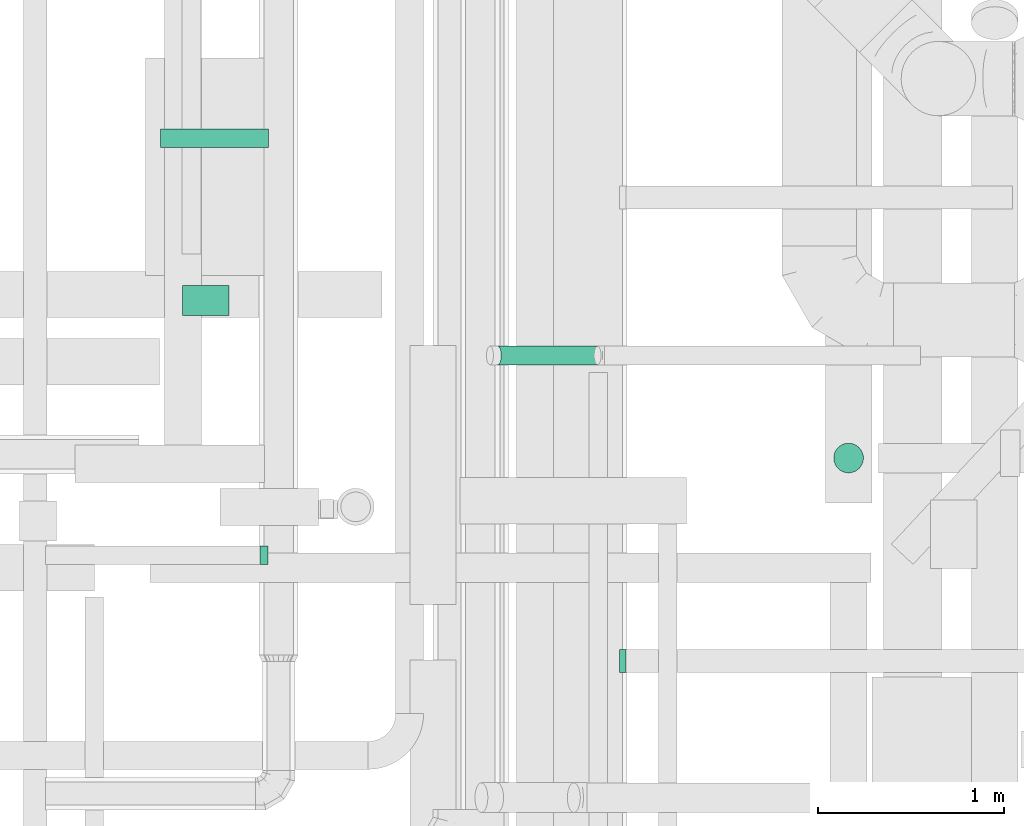
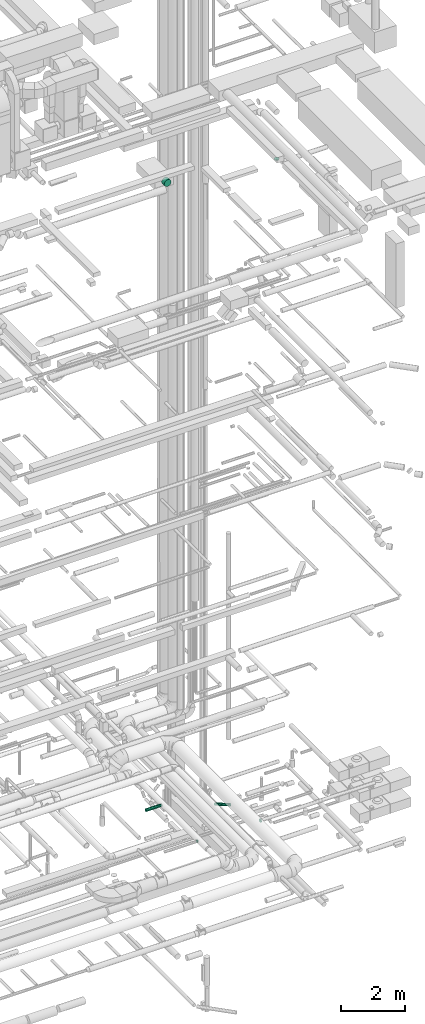
# One storey, part 214 of 337: 4 flow segments, 2 flow fittings.
"""IFC2X3 building model written with IfcOpenShell, lengths in millimetres."""

import ifcopenshell
import ifcopenshell.guid

model = None  # the IFC model being written
_history = None  # IfcOwnerHistory: only IFC2X3 demands one
_inside = {}  # id of a spatial element -> (the spatial element, [elements in it])
_under = {}  # id of a project, library or spatial element -> (it, [spatial elements below it])
_declared = {}  # id of a project -> (the project, [libraries it declares])
_typed = {}  # id of a type object -> (the type object, [elements of that type])
_made_of = {}  # id of a material, layer set ... -> (it, [elements and type objects made of it])


def new_model(schema):
    """Start an empty IFC model of exactly this schema.

    Asked for "IFC4X3", IfcOpenShell would pick the latest addendum, in which some entities
    have other attributes; the version numbers below select the first issue.
    IFC2X3 requires an IfcOwnerHistory on every rooted entity: one is made here for all.
    """
    global model, _history
    if schema == "IFC4X3":
        model = ifcopenshell.file(schema_version=(4, 3, 0, 0))
    else:
        model = ifcopenshell.file(schema=schema)
    _inside.clear()
    _under.clear()
    _declared.clear()
    _typed.clear()
    _made_of.clear()
    _history = None
    if model.schema == "IFC2X3":
        org = make("IfcOrganization", Name="unknown")
        user = make(
            "IfcPersonAndOrganization",
            ThePerson=make("IfcPerson", FamilyName="unknown"),
            TheOrganization=org,
        )
        app = make(
            "IfcApplication",
            ApplicationDeveloper=org,
            Version="unknown",
            ApplicationFullName="unknown",
            ApplicationIdentifier="unknown",
        )
        _history = make(
            "IfcOwnerHistory",
            OwningUser=user,
            OwningApplication=app,
            ChangeAction="ADDED",
            CreationDate=0,
        )
    return model


def make(cls, **values):
    """One entity of the class cls with the attributes given. An attribute that is None is left unset."""
    return model.create_entity(
        cls, **{name: value for name, value in values.items() if value is not None}
    )


def entity(cls, *values):
    """Any entity or typed value of the class cls, its attributes in the order of the schema. None: left unset."""
    e = model.create_entity(cls)
    for i, value in enumerate(values):
        if value is not None:
            e[i] = value
    return e


def rooted(cls, **values):
    """An entity with a GlobalId (a new one), such as an element, a storey or a relation."""
    return make(cls, GlobalId=ifcopenshell.guid.new(), OwnerHistory=_history, **values)


def si_unit(unit_type, name, prefix=None):
    """IfcSIUnit, for example si_unit("LENGTHUNIT", "METRE", prefix="MILLI")."""
    return make("IfcSIUnit", UnitType=unit_type, Prefix=prefix, Name=name)


def converted_unit(unit_type, name, factor, base, dimensions=None, offset=None):
    """IfcConversionBasedUnit, such as the inch: factor (a typed value) times the base unit."""
    return make(
        "IfcConversionBasedUnit"
        if offset is None
        else "IfcConversionBasedUnitWithOffset",
        ConversionOffset=offset,
        Dimensions=None
        if dimensions is None
        else entity("IfcDimensionalExponents", *dimensions),
        UnitType=unit_type,
        Name=name,
        ConversionFactor=make(
            "IfcMeasureWithUnit", ValueComponent=factor, UnitComponent=base
        ),
    )


def derived_unit(unit_type, elements):
    """IfcDerivedUnit: a product of units, each with its exponent."""
    return make(
        "IfcDerivedUnit",
        Elements=[
            make("IfcDerivedUnitElement", Unit=unit, Exponent=power)
            for unit, power in elements
        ],
        UnitType=unit_type,
    )


def assignment(units):
    """IfcUnitAssignment: the units of a project."""
    return None if units is None else make("IfcUnitAssignment", Units=units)


def point(xyz):
    """IfcCartesianPoint."""
    return None if xyz is None else make("IfcCartesianPoint", Coordinates=xyz)


def direction(xyz):
    """IfcDirection."""
    return None if xyz is None else make("IfcDirection", DirectionRatios=xyz)


def frame(location, z_axis=None, x_axis=None):
    """IfcAxis2Placement3D, a coordinate frame: its origin and axes. An axis left out is left unset."""
    return make(
        "IfcAxis2Placement3D",
        Location=point(location),
        Axis=direction(z_axis),
        RefDirection=direction(x_axis),
    )


def frame_2d(location, x_axis=None):
    """IfcAxis2Placement2D, a coordinate frame in the plane: its origin and x axis."""
    return make(
        "IfcAxis2Placement2D", Location=point(location), RefDirection=direction(x_axis)
    )


def origin():
    """The frame at (0, 0, 0) with its axes left unset."""
    return frame((0.0, 0.0, 0.0))


def origin_2d_with_axis():
    """The frame at (0, 0) in the plane with the x axis (1, 0) written out."""
    return frame_2d((0.0, 0.0), x_axis=(1.0, 0.0))


def place(relative_to, where):
    """IfcLocalPlacement: puts the frame where relative to a parent placement (None: the world)."""
    return make(
        "IfcLocalPlacement", PlacementRelTo=relative_to, RelativePlacement=where
    )


def context(
    kind, dimensions, precision=None, world=None, true_north=None, identifier=None
):
    """IfcGeometricRepresentationContext, for example the 3D "Model" context."""
    return make(
        "IfcGeometricRepresentationContext",
        ContextIdentifier=identifier,
        ContextType=kind,
        CoordinateSpaceDimension=dimensions,
        Precision=precision,
        WorldCoordinateSystem=world,
        TrueNorth=true_north,
    )


def subcontext(parent, identifier, kind, view, scale=None):
    """IfcGeometricRepresentationSubContext, for example "Body" below "Model"."""
    return make(
        "IfcGeometricRepresentationSubContext",
        ContextIdentifier=identifier,
        ContextType=kind,
        ParentContext=parent,
        TargetScale=scale,
        TargetView=view,
    )


def project(units=None, contexts=None):
    """IfcProject with its units and contexts."""
    return rooted(
        "IfcProject",
        Name="project",
        RepresentationContexts=contexts,
        UnitsInContext=assignment(units),
    )


def spatial(cls, under=None, at=None, **own):
    """A site, building, storey or space (cls), placed at a placement, below another one or the project."""
    s = rooted(cls, ObjectPlacement=at, **own)
    if under is not None:
        _under.setdefault(under.id(), (under, []))[1].append(s)
    return s


def profile(cls, at=None, kind="AREA", **sizes):
    """A parametric profile (cls). Its sizes go by their IFC names, for example OverallWidth=200.0."""
    return make(cls, ProfileType=kind, Position=at, **sizes)


def circle(**sizes):
    """IfcCircleProfileDef."""
    return profile("IfcCircleProfileDef", **sizes)


def extrude(swept, where, along, depth):
    """IfcExtrudedAreaSolid: the profile swept, set in the frame where, extruded along a direction by depth."""
    return make(
        "IfcExtrudedAreaSolid",
        SweptArea=swept,
        Position=where,
        ExtrudedDirection=direction(along),
        Depth=depth,
    )


def faces_of(points, faces, orient=None, outer=None):
    """IfcFace entities. A face is a list of loops; a loop is a list of indices into points, from 0.

    orient and outer hold one flag for each loop. By default every Orientation is true, the
    first loop of a face is its IfcFaceOuterBound and the others are IfcFaceBound.
    """
    made = []
    for i, loops in enumerate(faces):
        bounds = []
        for j, loop in enumerate(loops):
            is_outer = j == 0 if outer is None else outer[i][j]
            bounds.append(
                make(
                    "IfcFaceOuterBound" if is_outer else "IfcFaceBound",
                    Bound=make("IfcPolyLoop", Polygon=[points[k] for k in loop]),
                    Orientation=True if orient is None else orient[i][j],
                )
            )
        made.append(make("IfcFace", Bounds=bounds))
    return made


def faceted_brep(points, faces, orient=None, outer=None, voids=None):
    """IfcFacetedBrep: a solid bounded by flat faces; with voids (closed shells), ...WithVoids."""
    shared = [point(p) for p in points]
    hull = make("IfcClosedShell", CfsFaces=faces_of(shared, faces, orient, outer))
    if voids is None:
        return make("IfcFacetedBrep", Outer=hull)
    return make(
        "IfcFacetedBrepWithVoids",
        Outer=hull,
        Voids=[
            make(cls, CfsFaces=faces_of(shared, fs, o, b)) for cls, fs, o, b in voids
        ],
    )


def shape(context_of_items, identifier, shape_type, items):
    """IfcShapeRepresentation: the items that make up one representation, for example the "Body"."""
    return make(
        "IfcShapeRepresentation",
        ContextOfItems=context_of_items,
        RepresentationIdentifier=identifier,
        RepresentationType=shape_type,
        Items=items,
    )


def source(mapping_origin, context_of_items, identifier, shape_type, items):
    """IfcRepresentationMap: a shape defined once, which mapped items show again and again."""
    return make(
        "IfcRepresentationMap",
        MappingOrigin=mapping_origin,
        MappedRepresentation=shape(context_of_items, identifier, shape_type, items),
    )


def transform(
    local_origin,
    x_axis=None,
    y_axis=None,
    z_axis=None,
    scale=None,
    scale2=None,
    scale3=None,
    uniform=True,
):
    """IfcCartesianTransformationOperator3D, or its non-uniform kind. x_axis, y_axis, z_axis: its Axis1, 2, 3."""
    if uniform:
        return make(
            "IfcCartesianTransformationOperator3D",
            Axis1=direction(x_axis),
            Axis2=direction(y_axis),
            LocalOrigin=point(local_origin),
            Scale=scale,
            Axis3=direction(z_axis),
        )
    return make(
        "IfcCartesianTransformationOperator3DnonUniform",
        Axis1=direction(x_axis),
        Axis2=direction(y_axis),
        LocalOrigin=point(local_origin),
        Scale=scale,
        Axis3=direction(z_axis),
        Scale2=scale2,
        Scale3=scale3,
    )


def mapped(mapping_source, mapping_target):
    """IfcMappedItem: shows the shape of a source again, moved by a transform."""
    return make(
        "IfcMappedItem", MappingSource=mapping_source, MappingTarget=mapping_target
    )


def material(Name=None, Category=None):
    """IfcMaterial."""
    return make("IfcMaterial", Name=Name, Category=Category)


def made_of(thing, what):
    """Note that an element or type object is made of a material, layer set ...; save() writes the relation."""
    if what is not None:
        _made_of.setdefault(what.id(), (what, []))[1].append(thing)
    return thing


def type_object(cls, material=None, **own):
    """A type object (cls), such as IfcWallType, which elements share."""
    return made_of(rooted(cls, **own), material)


def type_shapes(of_type, sources):
    """Give a type object the sources (RepresentationMaps) that its elements show as mapped items."""
    of_type.RepresentationMaps = sources


def element(
    cls,
    number,
    at=None,
    inside=None,
    cuts=None,
    type_object=None,
    material=None,
    context=None,
    identifier="Body",
    shape_type=None,
    held_by="IfcProductDefinitionShape",
    body=None,
    shapes=None,
    **own,
):
    """One element of the class cls, such as IfcWall. Its Tag is "e" and its number.

    at: its placement. inside: the storey or other place that contains it. cuts: it is an
    opening in that element (IfcRelVoidsElement). A single representation is given by context,
    identifier, shape_type and body (its items); several are given by shapes. held_by: the class
    of the entity that holds the representations. save() writes the other relations.
    """
    e = rooted(cls, Tag="e%d" % number, ObjectPlacement=at, **own)
    if body is not None:
        shapes = [shape(context, identifier, shape_type, body)]
    if shapes is not None:
        e.Representation = make(held_by, Representations=shapes)
    if inside is not None:
        _inside.setdefault(inside.id(), (inside, []))[1].append(e)
    if cuts is not None:
        rooted(
            "IfcRelVoidsElement", RelatingBuildingElement=cuts, RelatedOpeningElement=e
        )
    if type_object is not None:
        _typed.setdefault(type_object.id(), (type_object, []))[1].append(e)
    return made_of(e, material)


def aggregate(whole, parts):
    """IfcRelAggregates: a whole, such as a stair, and the parts it consists of."""
    return rooted("IfcRelAggregates", RelatingObject=whole, RelatedObjects=parts)


def save(model, path):
    """Write the relations noted so far, then the file.

    IfcRelAggregates (storeys below a building ...), IfcRelContainedInSpatialStructure (elements
    in a storey), IfcRelDefinesByType, IfcRelAssociatesMaterial and IfcRelDeclares: one each for
    every whole, place, type object, material and project.
    """
    for whole, parts in _under.values():
        aggregate(whole, parts)
    for where, things in _inside.values():
        rooted(
            "IfcRelContainedInSpatialStructure",
            RelatedElements=things,
            RelatingStructure=where,
        )
    for kind, things in _typed.values():
        rooted("IfcRelDefinesByType", RelatedObjects=things, RelatingType=kind)
    for what, things in _made_of.values():
        rooted("IfcRelAssociatesMaterial", RelatedObjects=things, RelatingMaterial=what)
    for by, libraries in _declared.values():
        rooted("IfcRelDeclares", RelatingContext=by, RelatedDefinitions=libraries)
    model.write(path)


model = new_model("IFC2X3")

# Units and contexts
model_context = context("Model", 3, precision=0.01, world=origin(), true_north=direction((6.12303176911189e-17, 1.0)))
body_context = subcontext(model_context, "Body", "Model", "MODEL_VIEW")
ifc_project = project(units=[si_unit("LENGTHUNIT", "METRE", prefix="MILLI"), si_unit("AREAUNIT", "SQUARE_METRE"), si_unit("VOLUMEUNIT", "CUBIC_METRE"), converted_unit("PLANEANGLEUNIT", "DEGREE", entity("IfcRatioMeasure", 0.0174532925199433), si_unit("PLANEANGLEUNIT", "RADIAN"), dimensions=[0, 0, 0, 0, 0, 0, 0]), si_unit("MASSUNIT", "GRAM", prefix="KILO"), derived_unit("MASSDENSITYUNIT", [(si_unit("MASSUNIT", "GRAM", prefix="KILO"), 1), (si_unit("LENGTHUNIT", "METRE"), -3)]), derived_unit("MOMENTOFINERTIAUNIT", [(si_unit("LENGTHUNIT", "METRE"), 4)]), si_unit("TIMEUNIT", "SECOND"), si_unit("FREQUENCYUNIT", "HERTZ"), si_unit("THERMODYNAMICTEMPERATUREUNIT", "DEGREE_CELSIUS"), derived_unit("THERMALTRANSMITTANCEUNIT", [(si_unit("MASSUNIT", "GRAM", prefix="KILO"), 1), (si_unit("THERMODYNAMICTEMPERATUREUNIT", "KELVIN"), -1), (si_unit("TIMEUNIT", "SECOND"), -3)]), derived_unit("VOLUMETRICFLOWRATEUNIT", [(si_unit("LENGTHUNIT", "METRE"), 3), (si_unit("TIMEUNIT", "SECOND"), -1)]), derived_unit("MASSFLOWRATEUNIT", [(si_unit("MASSUNIT", "GRAM", prefix="KILO"), 1), (si_unit("TIMEUNIT", "SECOND"), -1)]), derived_unit("ROTATIONALFREQUENCYUNIT", [(si_unit("TIMEUNIT", "SECOND"), -1)]), si_unit("ELECTRICCURRENTUNIT", "AMPERE"), si_unit("ELECTRICVOLTAGEUNIT", "VOLT"), si_unit("POWERUNIT", "WATT"), si_unit("FORCEUNIT", "NEWTON", prefix="KILO"), si_unit("ILLUMINANCEUNIT", "LUX"), si_unit("LUMINOUSFLUXUNIT", "LUMEN"), si_unit("LUMINOUSINTENSITYUNIT", "CANDELA"), derived_unit("USERDEFINED", [(si_unit("MASSUNIT", "GRAM", prefix="KILO"), -1), (si_unit("LENGTHUNIT", "METRE"), -2), (si_unit("TIMEUNIT", "SECOND"), 3), (si_unit("LUMINOUSFLUXUNIT", "LUMEN"), 1)]), derived_unit("LINEARVELOCITYUNIT", [(si_unit("LENGTHUNIT", "METRE"), 1), (si_unit("TIMEUNIT", "SECOND"), -1)]), si_unit("PRESSUREUNIT", "PASCAL"), derived_unit("USERDEFINED", [(si_unit("LENGTHUNIT", "METRE"), -2), (si_unit("MASSUNIT", "GRAM", prefix="KILO"), 1), (si_unit("TIMEUNIT", "SECOND"), -2)]), derived_unit("LINEARFORCEUNIT", [(si_unit("MASSUNIT", "GRAM", prefix="KILO"), 1), (si_unit("LENGTHUNIT", "METRE"), 1), (si_unit("TIMEUNIT", "SECOND"), -2), (si_unit("LENGTHUNIT", "METRE"), -1)]), derived_unit("PLANARFORCEUNIT", [(si_unit("MASSUNIT", "GRAM", prefix="KILO"), 1), (si_unit("LENGTHUNIT", "METRE"), 1), (si_unit("TIMEUNIT", "SECOND"), -2), (si_unit("LENGTHUNIT", "METRE"), -2)])], contexts=[model_context])

# Site, building, storey
site_placement = place(None, origin())
site = spatial("IfcSite", under=ifc_project, at=site_placement, CompositionType="ELEMENT")
building_placement = place(site_placement, origin())
building = spatial("IfcBuilding", under=site, at=building_placement, CompositionType="ELEMENT")
storey_placement = place(building_placement, origin())
storey = spatial("IfcBuildingStorey", under=building, at=storey_placement, CompositionType="ELEMENT", Elevation=0.0)

# Flow segments
duct_segment_type = type_object("IfcDuctSegmentType", PredefinedType="NOTDEFINED")
flow_segment_1_placement = place(storey_placement, frame((67635.13, 5629.78, 27460.0)))
element("IfcFlowSegment", 1, at=flow_segment_1_placement, inside=storey, type_object=duct_segment_type, context=body_context, shape_type="SweptSolid", body=[
    extrude(circle(Radius=80.0, at=origin_2d_with_axis()), frame((81.6, 81.6, 0.0), z_axis=(0.0, 0.0, 1.0), x_axis=(0.0, -1.0, 0.0)), (0.0, 0.0, 1.0), 19.9999999999738),
])
flow_segment_2_placement = place(storey_placement, frame((64129.85, 6479.86, 27173.4)))
element("IfcFlowSegment", 2, at=flow_segment_2_placement, inside=storey, type_object=duct_segment_type, context=body_context, shape_type="SweptSolid", body=[
    extrude(circle(Radius=125.0, at=origin_2d_with_axis()), frame((126.6, 0.0, 126.6), z_axis=(0.0, 1.0, 0.0), x_axis=(1.0, 0.0, 0.0)), (0.0, 0.0, 1.0), 159.270196078255),
])
flow_segment_3_placement = place(storey_placement, frame((64013.27, 7382.06, 2998.4)))
element("IfcFlowSegment", 3, at=flow_segment_3_placement, inside=storey, type_object=duct_segment_type, context=body_context, shape_type="SweptSolid", body=[
    extrude(circle(Radius=50.0, at=origin_2d_with_axis()), frame((0.0, 51.6, 51.6), z_axis=(1.0, 0.0, 0.0), x_axis=(0.0, 1.0, 0.0)), (0.0, 0.0, 1.0), 579.999999999998),
])
flow_segment_4_placement = place(storey_placement, frame((65807.82, 6211.86, 3099.33)))
element("IfcFlowSegment", 4, at=flow_segment_4_placement, inside=storey, type_object=duct_segment_type, context=body_context, shape_type="SweptSolid", body=[
    extrude(circle(Radius=50.0, at=origin_2d_with_axis()), frame((557.87, 51.6, 47.95), z_axis=(-0.927183854566779, 0.0, 0.374606593415933), x_axis=(0.0, 1.0, 0.0)), (0.0, 0.0, 1.0), 579.755208113672),
])

# Flow fittings
ifc_material = material()
duct_fitting_type_1 = type_object("IfcDuctFittingType", PredefinedType="NOTDEFINED", material=ifc_material)
shared_shape_1 = source(origin(), body_context, "Body", "Brep", [
    faceted_brep([(20.0, 0.0, -50.0), (20.0, 12.94, -48.3), (20.0, 25.0, -43.3), (20.0, 35.36, -35.36), (20.0, 43.3, -25.0), (20.0, 48.3, -12.94), (20.0, 50.0, 0.0), (20.0, 48.3, 12.94), (20.0, 43.3, 25.0), (20.0, 35.36, 35.36), (20.0, 25.0, 43.3), (20.0, 12.94, 48.3), (20.0, 0.0, 50.0), (20.0, -12.94, 48.3), (20.0, -25.0, 43.3), (20.0, -35.36, 35.36), (20.0, -43.3, 25.0), (20.0, -48.3, 12.94), (20.0, -50.0, 0.0), (20.0, -48.3, -12.94), (20.0, -43.3, -25.0), (20.0, -35.36, -35.36), (20.0, -25.0, -43.3), (20.0, -12.94, -48.3), (0.0, 0.0, 50.0), (-23.65, 0.0, 50.0), (-23.65, -12.94, 48.3), (0.0, -12.94, 48.3), (-23.65, -25.0, 43.3), (0.0, -25.0, 43.3), (0.0, -35.36, 35.36), (-23.65, -35.36, 35.36), (0.0, -43.3, 25.0), (-23.65, -43.3, 25.0), (-23.65, -48.3, 12.94), (0.0, -48.3, 12.94), (-23.65, -50.0, 0.0), (0.0, -50.0, 0.0), (-23.65, -48.3, -12.94), (0.0, -48.3, -12.94), (-23.65, -43.3, -25.0), (0.0, -43.3, -25.0), (0.0, -35.36, -35.36), (-23.65, -35.36, -35.36), (0.0, -25.0, -43.3), (-23.65, -25.0, -43.3), (-23.65, -12.94, -48.3), (0.0, -12.94, -48.3), (-23.65, 0.0, -50.0), (0.0, 0.0, -50.0), (-23.65, 12.94, -48.3), (0.0, 12.94, -48.3), (-23.65, 25.0, -43.3), (0.0, 25.0, -43.3), (0.0, 35.36, -35.36), (-23.65, 35.36, -35.36), (0.0, 43.3, -25.0), (-23.65, 43.3, -25.0), (-23.65, 48.3, -12.94), (0.0, 48.3, -12.94), (-23.65, 50.0, 0.0), (0.0, 50.0, 0.0), (-23.65, 48.3, 12.94), (0.0, 48.3, 12.94), (-23.65, 43.3, 25.0), (0.0, 43.3, 25.0), (0.0, 35.36, 35.36), (-23.65, 35.36, 35.36), (0.0, 25.0, 43.3), (-23.65, 25.0, 43.3), (-23.65, 12.94, 48.3), (0.0, 12.94, 48.3)], [[[0, 1, 2, 3, 4, 5, 6, 7, 8, 9, 10, 11, 12, 13, 14, 15, 16, 17, 18, 19, 20, 21, 22, 23]], [[13, 12, 24, 25, 26, 27]], [[14, 13, 27, 26, 28, 29]], [[30, 15, 14, 29, 28, 31]], [[17, 16, 32, 33, 34, 35]], [[18, 17, 35, 34, 36, 37]], [[32, 16, 15, 30, 31, 33]], [[19, 18, 37, 36, 38, 39]], [[20, 19, 39, 38, 40, 41]], [[42, 21, 20, 41, 40, 43]], [[23, 22, 44, 45, 46, 47]], [[0, 23, 47, 46, 48, 49]], [[44, 22, 21, 42, 43, 45]], [[1, 0, 49, 48, 50, 51]], [[2, 1, 51, 50, 52, 53]], [[54, 3, 2, 53, 52, 55]], [[5, 4, 56, 57, 58, 59]], [[6, 5, 59, 58, 60, 61]], [[56, 4, 3, 54, 55, 57]], [[7, 6, 61, 60, 62, 63]], [[8, 7, 63, 62, 64, 65]], [[66, 9, 8, 65, 64, 67]], [[11, 10, 68, 69, 70, 71]], [[12, 11, 71, 70, 25, 24]], [[68, 10, 9, 66, 67, 69]], [[46, 45, 43, 40, 38, 36, 34, 33, 31, 28, 26, 25, 70, 69, 67, 64, 62, 60, 58, 57, 55, 52, 50, 48]]]),
])
type_shapes(duct_fitting_type_1, [shared_shape_1])
flow_fitting_1_placement = place(storey_placement, frame((64568.27, 5188.66, 3050.0), z_axis=(0.0, 0.0, -1.0), x_axis=(-1.0, 0.0, 0.0)))
element("IfcFlowFitting", 5, at=flow_fitting_1_placement, inside=storey, type_object=duct_fitting_type_1, material=ifc_material, context=body_context, shape_type="MappedRepresentation", body=[
    mapped(shared_shape_1, transform((0.0, 0.0, 0.0), scale=1.0)),
])
duct_fitting_type_2 = type_object("IfcDuctFittingType", PredefinedType="NOTDEFINED", material=ifc_material)
shared_shape_2 = source(origin(), body_context, "Body", "Brep", [
    faceted_brep([(20.0, 0.0, -62.5), (20.0, 16.18, -60.37), (20.0, 31.25, -54.13), (20.0, 44.19, -44.19), (20.0, 54.13, -31.25), (20.0, 60.37, -16.18), (20.0, 62.5, 0.0), (20.0, 60.37, 16.18), (20.0, 54.13, 31.25), (20.0, 44.19, 44.19), (20.0, 31.25, 54.13), (20.0, 16.18, 60.37), (20.0, 0.0, 62.5), (20.0, -16.18, 60.37), (20.0, -31.25, 54.13), (20.0, -44.19, 44.19), (20.0, -54.13, 31.25), (20.0, -60.37, 16.18), (20.0, -62.5, 0.0), (20.0, -60.37, -16.18), (20.0, -54.13, -31.25), (20.0, -44.19, -44.19), (20.0, -31.25, -54.13), (20.0, -16.18, -60.37), (0.0, 0.0, 62.5), (-16.11, 0.0, 62.5), (-16.11, -16.18, 60.37), (0.0, -16.18, 60.37), (-16.11, -31.25, 54.13), (0.0, -31.25, 54.13), (0.0, -44.19, 44.19), (-16.11, -44.19, 44.19), (0.0, -54.13, 31.25), (-16.11, -54.13, 31.25), (-16.11, -60.37, 16.18), (0.0, -60.37, 16.18), (-16.11, -62.5, 0.0), (0.0, -62.5, 0.0), (-16.11, -60.37, -16.18), (0.0, -60.37, -16.18), (-16.11, -54.13, -31.25), (0.0, -54.13, -31.25), (0.0, -44.19, -44.19), (-16.11, -44.19, -44.19), (0.0, -31.25, -54.13), (-16.11, -31.25, -54.13), (-16.11, -16.18, -60.37), (0.0, -16.18, -60.37), (-16.11, 0.0, -62.5), (0.0, 0.0, -62.5), (-16.11, 16.18, -60.37), (0.0, 16.18, -60.37), (-16.11, 31.25, -54.13), (0.0, 31.25, -54.13), (0.0, 44.19, -44.19), (-16.11, 44.19, -44.19), (0.0, 54.13, -31.25), (-16.11, 54.13, -31.25), (-16.11, 60.37, -16.18), (0.0, 60.37, -16.18), (-16.11, 62.5, 0.0), (0.0, 62.5, 0.0), (-16.11, 60.37, 16.18), (0.0, 60.37, 16.18), (-16.11, 54.13, 31.25), (0.0, 54.13, 31.25), (0.0, 44.19, 44.19), (-16.11, 44.19, 44.19), (0.0, 31.25, 54.13), (-16.11, 31.25, 54.13), (-16.11, 16.18, 60.37), (0.0, 16.18, 60.37)], [[[0, 1, 2, 3, 4, 5, 6, 7, 8, 9, 10, 11, 12, 13, 14, 15, 16, 17, 18, 19, 20, 21, 22, 23]], [[13, 12, 24, 25, 26, 27]], [[14, 13, 27, 26, 28, 29]], [[30, 15, 14, 29, 28, 31]], [[17, 16, 32, 33, 34, 35]], [[18, 17, 35, 34, 36, 37]], [[32, 16, 15, 30, 31, 33]], [[19, 18, 37, 36, 38, 39]], [[20, 19, 39, 38, 40, 41]], [[42, 21, 20, 41, 40, 43]], [[23, 22, 44, 45, 46, 47]], [[0, 23, 47, 46, 48, 49]], [[44, 22, 21, 42, 43, 45]], [[1, 0, 49, 48, 50, 51]], [[2, 1, 51, 50, 52, 53]], [[54, 3, 2, 53, 52, 55]], [[5, 4, 56, 57, 58, 59]], [[6, 5, 59, 58, 60, 61]], [[56, 4, 3, 54, 55, 57]], [[7, 6, 61, 60, 62, 63]], [[8, 7, 63, 62, 64, 65]], [[66, 9, 8, 65, 64, 67]], [[11, 10, 68, 69, 70, 71]], [[12, 11, 71, 70, 25, 24]], [[68, 10, 9, 66, 67, 69]], [[46, 45, 43, 40, 38, 36, 34, 33, 31, 28, 26, 25, 70, 69, 67, 64, 62, 60, 58, 57, 55, 52, 50, 48]]]),
])
type_shapes(duct_fitting_type_2, [shared_shape_2])
flow_fitting_2_placement = place(storey_placement, frame((66498.97, 4618.53, 3500.0), z_axis=(0.0, 0.0, -1.0), x_axis=(1.0, 0.0, 0.0)))
element("IfcFlowFitting", 6, at=flow_fitting_2_placement, inside=storey, type_object=duct_fitting_type_2, material=ifc_material, context=body_context, shape_type="MappedRepresentation", body=[
    mapped(shared_shape_2, transform((0.0, 0.0, 0.0), scale=1.0)),
])

save(model, "model.ifc")
